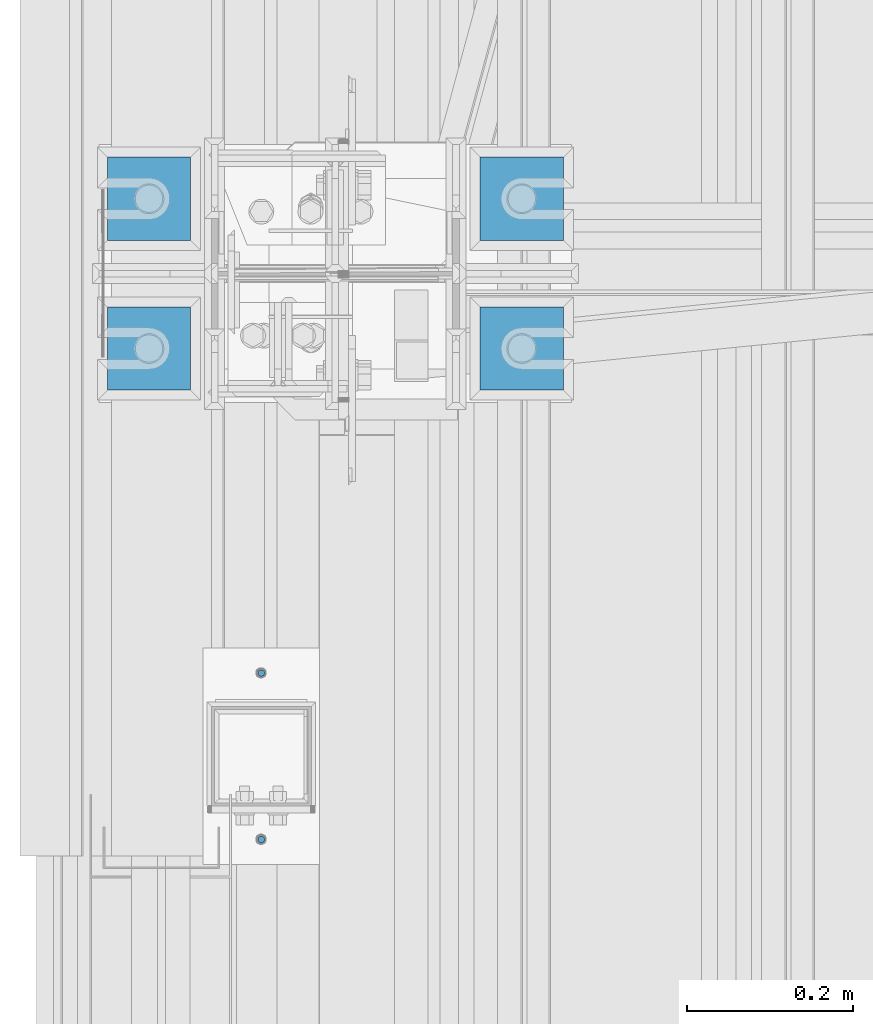
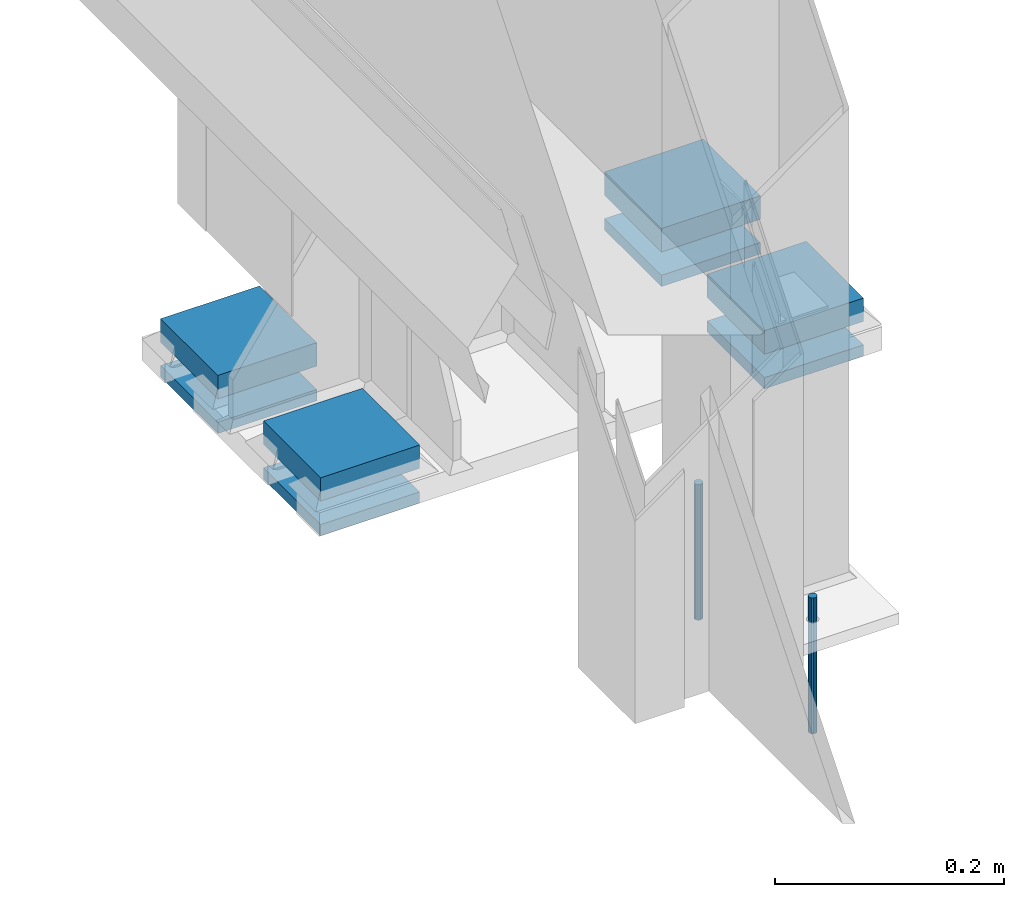
# One storey, part 88 of 709: 10 beams, 10 elements without a shape of their own.
"""IFC4 building model written with IfcOpenShell, lengths in millimetres."""

from ifc_helpers import new_model, si_unit, direction, frame, origin_with_axes, place, context, subcontext, project, spatial, line, indexed_curve, outline, extrude, material, element, aggregate, save


model = new_model("IFC4")

# Units and contexts
model_context = context("Model", 3, precision=0.2, world=origin_with_axes(), true_north=direction((0.0, 1.0)))
body_context = subcontext(model_context, "Body", "Model", "MODEL_VIEW")
ifc_project = project(units=[si_unit("LENGTHUNIT", "METRE", prefix="MILLI"), si_unit("AREAUNIT", "SQUARE_METRE"), si_unit("VOLUMEUNIT", "CUBIC_METRE"), si_unit("MASSUNIT", "GRAM", prefix="KILO"), si_unit("TIMEUNIT", "SECOND"), si_unit("PLANEANGLEUNIT", "RADIAN"), si_unit("SOLIDANGLEUNIT", "STERADIAN"), si_unit("THERMODYNAMICTEMPERATUREUNIT", "DEGREE_CELSIUS"), si_unit("LUMINOUSINTENSITYUNIT", "LUMEN")], contexts=[model_context])

# Site, building, storey
site_placement = place(None, origin_with_axes())
site = spatial("IfcSite", under=ifc_project, at=site_placement, CompositionType="ELEMENT")
building_placement = place(site_placement, origin_with_axes())
building = spatial("IfcBuilding", under=site, at=building_placement, Name="Undefined", CompositionType="ELEMENT")
storey_placement = place(building_placement, origin_with_axes())
storey = spatial("IfcBuildingStorey", under=building, at=storey_placement, Name="Undefined", CompositionType="ELEMENT", Elevation=0.0)

# Assembly, beam
assembly_1_placement = place(storey_placement, frame((-75.0, 5460.0, -162.5), z_axis=(0.0, 0.0, -1.0), x_axis=(0.0, -1.0, 0.0)))
assembly_1 = element("IfcElementAssembly", 1, at=assembly_1_placement, inside=storey)
ifc_material_1 = material(Name="C355-6", Category="STEEL")
beam_1_placement = place(assembly_1_placement, origin_with_axes())
beam_1 = element("IfcBeam", 2, at=beam_1_placement, material=ifc_material_1, ObjectType="421", context=body_context, shape_type="SolidModel", body=[
    extrude(outline(indexed_curve([(-12.5, -50.0), (12.5, -50.0), (12.5, 50.0), (-12.5, 50.0)], segments=[line(1, 2, 3, 4, 1)])), frame((0.0, 0.0, 0.0), z_axis=(-1.0, 0.0, 0.0), x_axis=(0.0, 0.0, 1.0)), (0.0, 0.0, -1.0), 100.0),
])
aggregate(assembly_1, [beam_1])

assembly_2_placement = place(storey_placement, frame((-75.0, 5460.0, -206.0), z_axis=(0.0, 0.0, -1.0), x_axis=(0.0, -1.0, 0.0)))
assembly_2 = element("IfcElementAssembly", 3, at=assembly_2_placement, inside=storey)
beam_2_placement = place(assembly_2_placement, origin_with_axes())
beam_2 = element("IfcBeam", 4, at=beam_2_placement, material=ifc_material_1, ObjectType="422", context=body_context, shape_type="SolidModel", body=[
    extrude(outline(indexed_curve([(-6.0, -50.0), (6.0, -50.0), (6.0, 50.0), (-6.0, 50.0)], segments=[line(1, 2, 3, 4, 1)])), frame((0.0, 0.0, 0.0), z_axis=(-1.0, 0.0, 0.0), x_axis=(0.0, 0.0, 1.0)), (0.0, 0.0, -1.0), 100.0),
])
aggregate(assembly_2, [beam_2])

assembly_3_placement = place(storey_placement, frame((373.0, 5460.0, -162.5), z_axis=(0.0, 0.0, -1.0), x_axis=(0.0, -1.0, 0.0)))
assembly_3 = element("IfcElementAssembly", 5, at=assembly_3_placement, inside=storey)
beam_3_placement = place(assembly_3_placement, origin_with_axes())
beam_3 = element("IfcBeam", 6, at=beam_3_placement, material=ifc_material_1, ObjectType="421", context=body_context, shape_type="SolidModel", body=[
    extrude(outline(indexed_curve([(-12.5, -50.0), (12.5, -50.0), (12.5, 50.0), (-12.5, 50.0)], segments=[line(1, 2, 3, 4, 1)])), frame((0.0, 0.0, 0.0), z_axis=(-1.0, 0.0, 0.0), x_axis=(0.0, 0.0, 1.0)), (0.0, 0.0, -1.0), 100.0),
])
aggregate(assembly_3, [beam_3])

assembly_4_placement = place(storey_placement, frame((373.0, 5460.0, -206.0), z_axis=(0.0, 0.0, -1.0), x_axis=(0.0, -1.0, 0.0)))
assembly_4 = element("IfcElementAssembly", 7, at=assembly_4_placement, inside=storey)
beam_4_placement = place(assembly_4_placement, origin_with_axes())
beam_4 = element("IfcBeam", 8, at=beam_4_placement, material=ifc_material_1, ObjectType="422", context=body_context, shape_type="SolidModel", body=[
    extrude(outline(indexed_curve([(-6.0, -50.0), (6.0, -50.0), (6.0, 50.0), (-6.0, 50.0)], segments=[line(1, 2, 3, 4, 1)])), frame((0.0, 0.0, 0.0), z_axis=(-1.0, 0.0, 0.0), x_axis=(0.0, 0.0, 1.0)), (0.0, 0.0, -1.0), 100.0),
])
aggregate(assembly_4, [beam_4])

assembly_5_placement = place(storey_placement, frame((-75.0, 5640.0, -162.5), z_axis=(0.0, 0.0, -1.0), x_axis=(0.0, -1.0, 0.0)))
assembly_5 = element("IfcElementAssembly", 9, at=assembly_5_placement, inside=storey)
beam_5_placement = place(assembly_5_placement, origin_with_axes())
beam_5 = element("IfcBeam", 10, at=beam_5_placement, material=ifc_material_1, ObjectType="421", context=body_context, shape_type="SolidModel", body=[
    extrude(outline(indexed_curve([(-12.5, -50.0), (12.5, -50.0), (12.5, 50.0), (-12.5, 50.0)], segments=[line(1, 2, 3, 4, 1)])), frame((0.0, 0.0, 0.0), z_axis=(-1.0, 0.0, 0.0), x_axis=(0.0, 0.0, 1.0)), (0.0, 0.0, -1.0), 100.0),
])
aggregate(assembly_5, [beam_5])

assembly_6_placement = place(storey_placement, frame((-75.0, 5640.0, -206.0), z_axis=(0.0, 0.0, -1.0), x_axis=(0.0, -1.0, 0.0)))
assembly_6 = element("IfcElementAssembly", 11, at=assembly_6_placement, inside=storey)
beam_6_placement = place(assembly_6_placement, origin_with_axes())
beam_6 = element("IfcBeam", 12, at=beam_6_placement, material=ifc_material_1, ObjectType="422", context=body_context, shape_type="SolidModel", body=[
    extrude(outline(indexed_curve([(-6.0, -50.0), (6.0, -50.0), (6.0, 50.0), (-6.0, 50.0)], segments=[line(1, 2, 3, 4, 1)])), frame((0.0, 0.0, 0.0), z_axis=(-1.0, 0.0, 0.0), x_axis=(0.0, 0.0, 1.0)), (0.0, 0.0, -1.0), 100.0),
])
aggregate(assembly_6, [beam_6])

assembly_7_placement = place(storey_placement, frame((373.0, 5640.0, -162.5), z_axis=(0.0, 0.0, -1.0), x_axis=(0.0, -1.0, 0.0)))
assembly_7 = element("IfcElementAssembly", 13, at=assembly_7_placement, inside=storey)
beam_7_placement = place(assembly_7_placement, origin_with_axes())
beam_7 = element("IfcBeam", 14, at=beam_7_placement, material=ifc_material_1, ObjectType="421", context=body_context, shape_type="SolidModel", body=[
    extrude(outline(indexed_curve([(-12.5, -50.0), (12.5, -50.0), (12.5, 50.0), (-12.5, 50.0)], segments=[line(1, 2, 3, 4, 1)])), frame((0.0, 0.0, 0.0), z_axis=(-1.0, 0.0, 0.0), x_axis=(0.0, 0.0, 1.0)), (0.0, 0.0, -1.0), 100.0),
])
aggregate(assembly_7, [beam_7])

assembly_8_placement = place(storey_placement, frame((373.0, 5640.0, -206.0), z_axis=(0.0, 0.0, -1.0), x_axis=(0.0, -1.0, 0.0)))
assembly_8 = element("IfcElementAssembly", 15, at=assembly_8_placement, inside=storey)
beam_8_placement = place(assembly_8_placement, origin_with_axes())
beam_8 = element("IfcBeam", 16, at=beam_8_placement, material=ifc_material_1, ObjectType="422", context=body_context, shape_type="SolidModel", body=[
    extrude(outline(indexed_curve([(-6.0, -50.0), (6.0, -50.0), (6.0, 50.0), (-6.0, 50.0)], segments=[line(1, 2, 3, 4, 1)])), frame((0.0, 0.0, 0.0), z_axis=(-1.0, 0.0, 0.0), x_axis=(0.0, 0.0, 1.0)), (0.0, 0.0, -1.0), 100.0),
])
aggregate(assembly_8, [beam_8])

assembly_9_placement = place(storey_placement, frame((60.0, 4820.0, -13.0), z_axis=(0.0, -1.0, 0.0), x_axis=(0.0, 0.0, -1.0)))
assembly_9 = element("IfcElementAssembly", 17, at=assembly_9_placement, inside=storey)
ifc_material_2 = material(Name="Steel_Undefined", Category="STEEL")
beam_9_placement = place(assembly_9_placement, origin_with_axes())
beam_9 = element("IfcBeam", 18, at=beam_9_placement, material=ifc_material_2, context=body_context, shape_type="SolidModel", body=[
    extrude(outline(indexed_curve([(4.0, 0.0), (3.69552, 1.53073), (2.82843, 2.82843), (1.53073, 3.69552), (0.0, 4.0), (-1.53073, 3.69552), (-2.82843, 2.82843), (-3.69552, 1.53073), (-4.0, 0.0), (-3.69552, -1.53073), (-2.82843, -2.82843), (-1.53073, -3.69552), (0.0, -4.0), (1.53073, -3.69552), (2.82843, -2.82843), (3.69552, -1.53073)], segments=[line(1, 2, 3, 4, 5, 6, 7, 8, 9, 10, 11, 12, 13, 14, 15, 16, 1)])), frame((0.0, 0.0, 0.0), z_axis=(-1.0, 0.0, 0.0), x_axis=(0.0, 0.0, 1.0)), (0.0, 0.0, -1.0), 145.0),
])
aggregate(assembly_9, [beam_9])

assembly_10_placement = place(storey_placement, frame((60.0, 5020.0, -13.0), z_axis=(0.0, -1.0, 0.0), x_axis=(0.0, 0.0, -1.0)))
assembly_10 = element("IfcElementAssembly", 19, at=assembly_10_placement, inside=storey)
beam_10_placement = place(assembly_10_placement, origin_with_axes())
beam_10 = element("IfcBeam", 20, at=beam_10_placement, material=ifc_material_2, context=body_context, shape_type="SolidModel", body=[
    extrude(outline(indexed_curve([(4.0, 0.0), (3.69552, 1.53073), (2.82843, 2.82843), (1.53073, 3.69552), (0.0, 4.0), (-1.53073, 3.69552), (-2.82843, 2.82843), (-3.69552, 1.53073), (-4.0, 0.0), (-3.69552, -1.53073), (-2.82843, -2.82843), (-1.53073, -3.69552), (0.0, -4.0), (1.53073, -3.69552), (2.82843, -2.82843), (3.69552, -1.53073)], segments=[line(1, 2, 3, 4, 5, 6, 7, 8, 9, 10, 11, 12, 13, 14, 15, 16, 1)])), frame((0.0, 0.0, 0.0), z_axis=(-1.0, 0.0, 0.0), x_axis=(0.0, 0.0, 1.0)), (0.0, 0.0, -1.0), 145.0),
])
aggregate(assembly_10, [beam_10])

save(model, "model.ifc")
